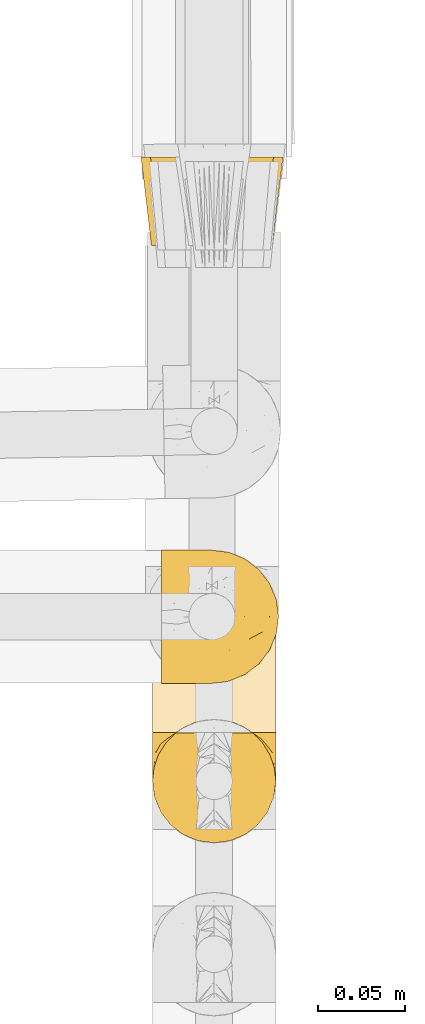
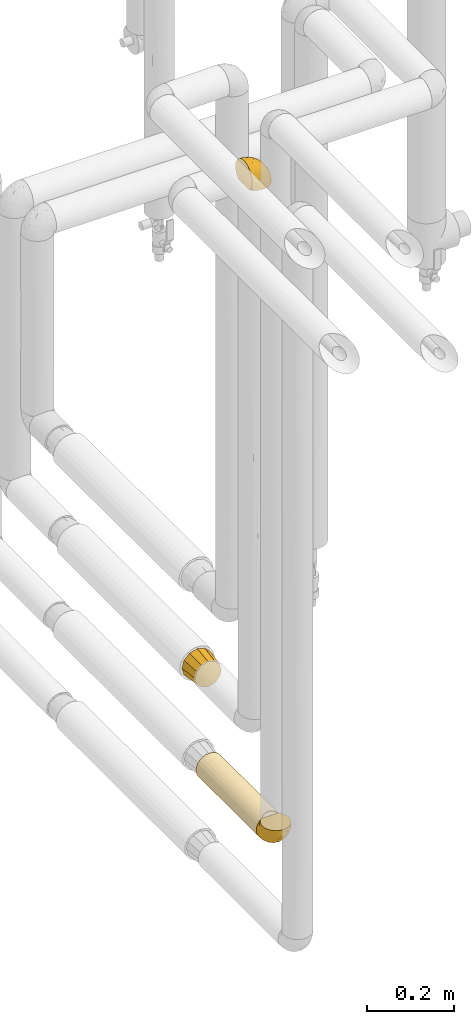
# One storey, part 73 of 827: 4 coverings.
"""IFC2X3 building model written with IfcOpenShell, lengths in millimetres."""

from ifc_helpers import new_model, entity, si_unit, converted_unit, derived_unit, direction, frame, origin, place, context, subcontext, project, spatial, faceted_brep, element, save


model = new_model("IFC2X3")

# Units and contexts
model_context = context("Model", 3, precision=0.01, world=origin(), true_north=direction((6.12303176911189e-17, 1.0)))
body_context = subcontext(model_context, "Body", "Model", "MODEL_VIEW")
ifc_project = project(units=[si_unit("LENGTHUNIT", "METRE", prefix="MILLI"), si_unit("AREAUNIT", "SQUARE_METRE"), si_unit("VOLUMEUNIT", "CUBIC_METRE"), converted_unit("PLANEANGLEUNIT", "DEGREE", entity("IfcRatioMeasure", 0.0174532925199433), si_unit("PLANEANGLEUNIT", "RADIAN"), dimensions=[0, 0, 0, 0, 0, 0, 0]), si_unit("MASSUNIT", "GRAM", prefix="KILO"), derived_unit("MASSDENSITYUNIT", [(si_unit("MASSUNIT", "GRAM", prefix="KILO"), 1), (si_unit("LENGTHUNIT", "METRE"), -3)]), derived_unit("MOMENTOFINERTIAUNIT", [(si_unit("LENGTHUNIT", "METRE"), 4)]), si_unit("TIMEUNIT", "SECOND"), si_unit("FREQUENCYUNIT", "HERTZ"), si_unit("THERMODYNAMICTEMPERATUREUNIT", "DEGREE_CELSIUS"), derived_unit("THERMALTRANSMITTANCEUNIT", [(si_unit("MASSUNIT", "GRAM", prefix="KILO"), 1), (si_unit("THERMODYNAMICTEMPERATUREUNIT", "KELVIN"), -1), (si_unit("TIMEUNIT", "SECOND"), -3)]), derived_unit("VOLUMETRICFLOWRATEUNIT", [(si_unit("LENGTHUNIT", "METRE"), 3), (si_unit("TIMEUNIT", "SECOND"), -1)]), derived_unit("MASSFLOWRATEUNIT", [(si_unit("MASSUNIT", "GRAM", prefix="KILO"), 1), (si_unit("TIMEUNIT", "SECOND"), -1)]), derived_unit("ROTATIONALFREQUENCYUNIT", [(si_unit("TIMEUNIT", "SECOND"), -1)]), si_unit("ELECTRICCURRENTUNIT", "AMPERE"), si_unit("ELECTRICVOLTAGEUNIT", "VOLT"), si_unit("POWERUNIT", "WATT"), si_unit("FORCEUNIT", "NEWTON", prefix="KILO"), si_unit("ILLUMINANCEUNIT", "LUX"), si_unit("LUMINOUSFLUXUNIT", "LUMEN"), si_unit("LUMINOUSINTENSITYUNIT", "CANDELA"), derived_unit("USERDEFINED", [(si_unit("MASSUNIT", "GRAM", prefix="KILO"), -1), (si_unit("LENGTHUNIT", "METRE"), -2), (si_unit("TIMEUNIT", "SECOND"), 3), (si_unit("LUMINOUSFLUXUNIT", "LUMEN"), 1)]), derived_unit("LINEARVELOCITYUNIT", [(si_unit("LENGTHUNIT", "METRE"), 1), (si_unit("TIMEUNIT", "SECOND"), -1)]), si_unit("PRESSUREUNIT", "PASCAL"), derived_unit("USERDEFINED", [(si_unit("LENGTHUNIT", "METRE"), -2), (si_unit("MASSUNIT", "GRAM", prefix="KILO"), 1), (si_unit("TIMEUNIT", "SECOND"), -2)]), derived_unit("LINEARFORCEUNIT", [(si_unit("MASSUNIT", "GRAM", prefix="KILO"), 1), (si_unit("LENGTHUNIT", "METRE"), 1), (si_unit("TIMEUNIT", "SECOND"), -2), (si_unit("LENGTHUNIT", "METRE"), -1)]), derived_unit("PLANARFORCEUNIT", [(si_unit("MASSUNIT", "GRAM", prefix="KILO"), 1), (si_unit("LENGTHUNIT", "METRE"), 1), (si_unit("TIMEUNIT", "SECOND"), -2), (si_unit("LENGTHUNIT", "METRE"), -2)])], contexts=[model_context])

# Site, building, storey
site_placement = place(None, origin())
site = spatial("IfcSite", under=ifc_project, at=site_placement, CompositionType="ELEMENT")
building_placement = place(site_placement, origin())
building = spatial("IfcBuilding", under=site, at=building_placement, CompositionType="ELEMENT")
storey_placement = place(building_placement, frame((0.0, 0.0, 28200.0)))
storey = spatial("IfcBuildingStorey", under=building, at=storey_placement, Name="08", CompositionType="ELEMENT", Elevation=28200.0)

# Coverings
covering_1_placement = place(storey_placement, frame((17896.58, 10716.18, 2621.03)))
element("IfcCovering", 1, at=covering_1_placement, inside=storey, Name=":ADSK_", ObjectType=":ADSK_", PredefinedType="INSULATION", context=body_context, shape_type="Brep", body=[
    faceted_brep([(1.6, 5.41, 47.38), (1.6, 9.99, 54.67), (1.6, 16.08, 60.76), (1.6, 23.37, 65.34), (1.6, 31.49, 68.18), (1.6, 40.05, 69.15), (1.6, 48.61, 68.18), (1.6, 56.73, 65.33), (1.6, 64.02, 60.75), (1.6, 70.11, 54.66), (1.6, 74.69, 47.37), (1.6, 77.53, 39.25), (1.6, 78.5, 30.7), (1.6, 77.63, 22.59), (1.6, 75.08, 14.86), (1.6, 70.97, 7.84), (1.6, 65.47, 1.85), (1.6, 63.27, 1.85), (1.6, 61.53, 1.85), (1.6, 59.57, 1.85), (1.6, 57.6, 1.85), (1.6, 55.63, 1.85), (1.6, 53.67, 1.85), (1.6, 51.7, 1.85), (1.6, 49.73, 1.85), (1.6, 47.54, 1.85), (1.6, 45.34, 1.85), (1.6, 43.15, 1.85), (1.6, 40.96, 1.85), (1.6, 38.76, 1.85), (1.6, 36.57, 1.85), (1.6, 34.37, 1.85), (1.6, 32.18, 1.85), (1.6, 29.98, 1.85), (1.6, 27.79, 1.85), (1.6, 25.6, 1.85), (1.6, 23.4, 1.85), (1.6, 21.21, 1.85), (1.6, 19.01, 1.85), (1.6, 16.82, 1.85), (1.6, 14.62, 1.85), (1.6, 9.12, 7.85), (1.6, 5.0, 14.88), (1.6, 2.46, 22.61), (1.6, 1.6, 30.7), (1.6, 2.56, 39.26), (1.85, 65.47, 1.6), (7.85, 70.97, 1.6), (14.87, 75.09, 1.6), (22.6, 77.63, 1.6), (30.7, 78.5, 1.6), (40.65, 77.19, 1.6), (49.92, 73.34, 1.6), (57.88, 67.23, 1.6), (63.99, 59.27, 1.6), (67.84, 50.0, 1.6), (69.15, 40.05, 1.6), (67.84, 30.09, 1.6), (63.99, 20.82, 1.6), (57.88, 12.86, 1.6), (49.92, 6.75, 1.6), (40.65, 2.91, 1.6), (30.7, 1.6, 1.6), (22.6, 2.46, 1.6), (14.87, 5.0, 1.6), (7.85, 9.12, 1.6), (1.85, 14.62, 1.6), (1.85, 16.82, 1.6), (1.85, 17.8, 1.6), (1.85, 19.39, 1.6), (1.85, 20.98, 1.6), (1.85, 22.57, 1.6), (1.85, 24.16, 1.6), (1.85, 25.75, 1.6), (1.85, 27.33, 1.6), (1.85, 28.92, 1.6), (1.85, 30.51, 1.6), (1.85, 32.1, 1.6), (1.85, 33.69, 1.6), (1.85, 35.28, 1.6), (1.85, 36.87, 1.6), (1.85, 38.46, 1.6), (1.85, 40.05, 1.6), (1.85, 41.63, 1.6), (1.85, 43.22, 1.6), (1.85, 44.81, 1.6), (1.85, 46.4, 1.6), (1.85, 47.99, 1.6), (1.85, 49.58, 1.6), (1.85, 51.17, 1.6), (1.85, 52.76, 1.6), (1.85, 54.72, 1.6), (1.85, 56.69, 1.6), (1.85, 58.88, 1.6), (1.85, 61.08, 1.6), (1.85, 63.27, 1.6), (1.77, 37.77, 1.78), (1.78, 36.07, 1.77), (1.77, 32.96, 1.78), (1.77, 31.36, 1.77), (1.76, 56.52, 1.79), (1.77, 54.96, 1.78), (1.79, 18.75, 1.76), (1.78, 58.07, 1.77), (1.78, 50.37, 1.77), (1.78, 23.36, 1.76), (1.78, 24.95, 1.77), (1.78, 42.43, 1.77), (1.74, 15.97, 1.8), (1.78, 51.96, 1.76), (1.78, 53.47, 1.77), (1.77, 48.63, 1.78), (1.78, 63.93, 1.77), (1.78, 40.93, 1.77), (1.78, 29.72, 1.76), (1.77, 62.4, 1.77), (1.77, 60.92, 1.78), (1.77, 17.31, 1.77), (1.78, 21.74, 1.77), (1.78, 34.56, 1.77), (1.77, 20.18, 1.78), (1.77, 14.62, 1.77), (1.72, 14.62, 1.8), (1.66, 14.62, 1.82), (1.77, 65.47, 1.77), (1.8, 65.47, 1.72), (1.82, 65.47, 1.66), (1.79, 59.5, 1.76), (1.78, 47.1, 1.77), (1.79, 45.61, 1.76), (1.78, 28.18, 1.77), (1.82, 14.62, 1.66), (1.8, 14.62, 1.72), (1.76, 26.61, 1.78), (1.66, 65.47, 1.82), (1.72, 65.47, 1.8), (1.78, 39.32, 1.77), (1.77, 44.12, 1.78), (9.41, 72.26, 3.72), (17.65, 76.57, 7.41), (7.41, 71.77, 6.13), (21.47, 78.5, 21.47), (15.21, 77.9, 19.34), (16.15, 78.5, 26.8), (28.75, 78.5, 8.87), (13.67, 75.52, 9.2), (12.79, 76.13, 12.79), (19.18, 77.81, 14.62), (29.16, 78.5, 7.34), (9.04, 72.4, 5.33), (7.41, 76.56, 17.64), (5.74, 71.77, 7.7), (3.72, 72.25, 9.41), (8.87, 78.5, 28.75), (26.8, 78.5, 16.15), (9.53, 75.75, 14.14), (7.34, 78.5, 29.16), (37.63, 50.46, 57.02), (17.92, 52.75, 64.92), (27.45, 40.05, 64.0), (37.01, 77.7, 11.92), (34.22, 77.66, 19.16), (45.87, 71.02, 28.65), (56.57, 63.45, 24.62), (52.31, 70.55, 15.19), (42.07, 75.57, 18.36), (44.74, 75.57, 9.2), (21.49, 72.61, 46.98), (11.02, 72.61, 50.24), (15.64, 67.24, 56.1), (26.02, 77.74, 28.97), (36.59, 57.43, 54.46), (65.49, 47.19, 21.34), (63.99, 54.76, 18.4), (15.2, 40.05, 66.44), (60.27, 63.45, 12.07), (45.25, 60.1, 45.49), (35.21, 63.72, 50.57), (22.52, 76.83, 36.04), (12.03, 76.34, 42.07), (13.32, 60.51, 62.12), (35.9, 72.59, 37.37), (33.87, 76.05, 29.39), (25.73, 66.15, 53.59), (26.34, 60.51, 58.06), (46.78, 51.88, 49.27), (59.54, 55.34, 29.63), (60.18, 48.67, 33.21), (53.93, 53.89, 40.1), (53.36, 46.73, 44.08), (49.36, 40.05, 49.36), (38.4, 40.05, 56.68), (66.44, 40.05, 15.2), (50.09, 63.95, 35.57), (41.08, 67.24, 41.7), (31.14, 69.62, 46.4), (28.19, 73.6, 41.41), (64.0, 40.05, 27.45), (56.68, 40.05, 38.4), (43.9, 4.52, 12.99), (65.46, 32.72, 21.33), (52.22, 27.18, 42.89), (37.61, 29.63, 57.04), (15.64, 12.86, 56.11), (13.31, 19.59, 62.13), (50.02, 9.54, 21.89), (59.28, 16.64, 16.62), (53.05, 17.48, 32.9), (21.48, 7.49, 46.99), (11.01, 7.49, 50.25), (12.03, 3.75, 42.08), (41.02, 20.75, 49.91), (35.39, 2.33, 15.6), (26.8, 1.6, 16.15), (28.75, 1.6, 8.87), (7.34, 1.6, 29.16), (65.81, 26.94, 13.16), (53.28, 9.54, 10.83), (59.8, 31.21, 33.8), (61.82, 25.33, 25.02), (17.91, 27.35, 64.92), (41.4, 8.17, 32.83), (40.48, 4.3, 20.56), (26.34, 19.59, 58.07), (31.68, 2.23, 21.46), (27.68, 2.45, 28.1), (16.15, 1.6, 26.8), (21.47, 1.6, 21.47), (28.05, 12.86, 51.29), (22.54, 3.27, 36.04), (8.87, 1.6, 28.75), (37.3, 2.29, 8.45), (41.07, 12.86, 41.73), (32.24, 6.89, 39.27), (47.4, 12.43, 33.56), (35.77, 4.1, 27.29), (17.65, 3.53, 7.41), (11.06, 6.88, 3.51), (8.55, 8.16, 4.68), (6.63, 9.02, 5.52), (12.77, 5.0, 8.75), (12.79, 3.96, 12.79), (7.41, 3.52, 17.65), (18.97, 2.4, 13.9), (3.72, 7.83, 9.42), (5.76, 8.32, 7.68), (15.21, 2.19, 19.33), (9.52, 4.34, 14.13)], [[[0, 1, 2, 3, 4, 5, 6, 7, 8, 9, 10, 11, 12, 13, 14, 15, 16, 17, 18, 19, 20, 21, 22, 23, 24, 25, 26, 27, 28, 29, 30, 31, 32, 33, 34, 35, 36, 37, 38, 39, 40, 41, 42, 43, 44, 45]], [[46, 47, 48, 49, 50, 51, 52, 53, 54, 55, 56, 57, 58, 59, 60, 61, 62, 63, 64, 65, 66, 67, 68, 69, 70, 71, 72, 73, 74, 75, 76, 77, 78, 79, 80, 81, 82, 83, 84, 85, 86, 87, 88, 89, 90, 91, 92, 93, 94, 95]], [[96, 97, 30]], [[98, 77, 99]], [[100, 101, 21]], [[69, 68, 102]], [[20, 19, 103]], [[24, 23, 104]], [[20, 103, 100]], [[72, 105, 106]], [[84, 83, 107]], [[89, 88, 104]], [[108, 67, 66]], [[109, 110, 90]], [[111, 25, 24]], [[112, 17, 16]], [[82, 113, 83]], [[109, 23, 22]], [[114, 76, 75]], [[105, 36, 106]], [[104, 111, 24]], [[18, 115, 116]], [[97, 96, 80]], [[67, 108, 117]], [[105, 71, 118]], [[31, 97, 119]], [[102, 120, 69]], [[108, 121, 122, 123, 40]], [[112, 95, 115]], [[17, 115, 18]], [[94, 116, 115]], [[117, 68, 67]], [[38, 117, 39]], [[112, 124, 125, 126, 46]], [[17, 112, 115]], [[70, 120, 118]], [[39, 117, 108]], [[120, 38, 37]], [[120, 37, 118]], [[120, 70, 69]], [[116, 94, 127]], [[128, 86, 129]], [[117, 38, 102]], [[74, 130, 75]], [[99, 33, 32]], [[115, 95, 94]], [[39, 108, 40]], [[108, 66, 131, 132, 121]], [[105, 72, 71]], [[118, 37, 36]], [[71, 70, 118]], [[35, 106, 36]], [[36, 105, 118]], [[35, 133, 106]], [[74, 73, 133]], [[106, 133, 73]], [[99, 114, 33]], [[133, 35, 34]], [[73, 72, 106]], [[95, 112, 46]], [[112, 16, 134, 135, 124]], [[130, 114, 75]], [[99, 76, 114]], [[114, 130, 33]], [[34, 33, 130]], [[78, 77, 98]], [[98, 119, 78]], [[130, 133, 34]], [[133, 130, 74]], [[79, 97, 80]], [[98, 99, 32]], [[98, 32, 31]], [[77, 76, 99]], [[97, 79, 119]], [[136, 96, 29]], [[30, 97, 31]], [[136, 29, 28]], [[81, 80, 96]], [[29, 96, 30]], [[31, 119, 98]], [[119, 79, 78]], [[96, 136, 81]], [[82, 81, 136]], [[113, 107, 83]], [[84, 107, 137]], [[107, 27, 137]], [[113, 28, 107]], [[27, 107, 28]], [[85, 84, 137]], [[137, 27, 26]], [[113, 136, 28]], [[136, 113, 82]], [[109, 89, 104]], [[86, 85, 129]], [[89, 109, 90]], [[111, 87, 128]], [[26, 129, 137]], [[88, 111, 104]], [[25, 111, 128]], [[22, 110, 109]], [[23, 109, 104]], [[110, 91, 90]], [[100, 92, 101]], [[110, 22, 101]], [[91, 110, 101]], [[116, 19, 18]], [[111, 88, 87]], [[127, 103, 19]], [[25, 128, 26]], [[86, 128, 87]], [[128, 129, 26]], [[137, 129, 85]], [[120, 102, 38]], [[117, 102, 68]], [[91, 101, 92]], [[21, 101, 22]], [[93, 92, 103]], [[100, 21, 20]], [[100, 103, 92]], [[127, 93, 103]], [[93, 127, 94]], [[116, 127, 19]], [[126, 138, 47]], [[48, 138, 139]], [[140, 125, 124]], [[141, 142, 143]], [[144, 49, 139]], [[145, 140, 146]], [[48, 139, 49]], [[139, 145, 147]], [[49, 144, 148, 50]], [[126, 125, 149]], [[14, 13, 150]], [[151, 146, 140]], [[149, 140, 145]], [[152, 151, 135]], [[152, 14, 150]], [[16, 15, 134]], [[13, 153, 150]], [[124, 151, 140]], [[141, 147, 142]], [[14, 152, 15]], [[15, 152, 134]], [[47, 46, 126]], [[139, 154, 144]], [[138, 48, 47]], [[125, 140, 149]], [[135, 134, 152]], [[146, 155, 142]], [[145, 146, 147]], [[149, 139, 138]], [[147, 141, 154]], [[147, 146, 142]], [[139, 147, 154]], [[139, 149, 145]], [[149, 138, 126]], [[155, 146, 151]], [[150, 143, 142]], [[152, 155, 151]], [[150, 142, 155]], [[13, 12, 156, 153]], [[153, 143, 150]], [[152, 150, 155]], [[151, 124, 135]], [[157, 158, 159]], [[160, 154, 161]], [[162, 163, 164]], [[165, 166, 160]], [[167, 168, 169]], [[141, 170, 161]], [[156, 12, 11]], [[158, 157, 171]], [[172, 55, 173]], [[158, 6, 174]], [[175, 54, 53]], [[52, 166, 164]], [[52, 164, 53]], [[54, 175, 173]], [[166, 52, 51]], [[176, 177, 171]], [[178, 143, 179]], [[156, 11, 179]], [[8, 7, 180]], [[169, 9, 8]], [[179, 143, 153, 156]], [[179, 11, 10]], [[168, 179, 10]], [[181, 162, 182]], [[179, 167, 178]], [[183, 184, 177]], [[183, 169, 184]], [[176, 171, 185]], [[172, 186, 187]], [[158, 7, 6]], [[159, 158, 174]], [[184, 180, 158]], [[54, 173, 55]], [[180, 169, 8]], [[188, 189, 187]], [[9, 168, 10]], [[186, 188, 187]], [[190, 157, 159, 191]], [[55, 172, 192]], [[176, 193, 194]], [[161, 170, 182]], [[162, 164, 165]], [[175, 164, 163]], [[51, 50, 148]], [[167, 195, 196]], [[178, 182, 170]], [[6, 5, 174]], [[158, 180, 7]], [[169, 180, 184]], [[169, 168, 9]], [[179, 168, 167]], [[182, 162, 165]], [[162, 194, 193]], [[161, 165, 160]], [[195, 181, 196]], [[192, 172, 197]], [[192, 56, 55]], [[189, 190, 198]], [[198, 197, 187]], [[172, 187, 197]], [[185, 189, 188]], [[198, 187, 189]], [[186, 172, 173]], [[173, 163, 186]], [[193, 186, 163]], [[176, 185, 188]], [[185, 157, 190]], [[188, 186, 193]], [[177, 176, 194]], [[188, 193, 176]], [[162, 193, 163]], [[195, 177, 194]], [[171, 177, 184]], [[181, 195, 194]], [[183, 167, 169]], [[162, 181, 194]], [[196, 182, 178]], [[158, 171, 184]], [[171, 157, 185]], [[177, 195, 183]], [[167, 183, 195]], [[182, 196, 181]], [[178, 170, 143]], [[178, 167, 196]], [[164, 175, 53]], [[173, 175, 163]], [[160, 51, 148]], [[164, 166, 165]], [[51, 160, 166]], [[160, 148, 144, 154]], [[141, 161, 154]], [[182, 165, 161]], [[190, 189, 185]], [[143, 170, 141]], [[60, 199, 61]], [[197, 200, 192]], [[201, 190, 202]], [[200, 57, 192]], [[203, 204, 2]], [[205, 206, 207]], [[208, 209, 210]], [[211, 207, 201]], [[212, 213, 214]], [[45, 215, 210]], [[216, 206, 58]], [[45, 44, 215]], [[59, 217, 60]], [[60, 217, 199]], [[0, 45, 210]], [[218, 201, 219]], [[202, 159, 220]], [[205, 221, 222]], [[223, 204, 203]], [[1, 203, 2]], [[57, 200, 216]], [[220, 3, 204]], [[220, 174, 4]], [[1, 0, 209]], [[212, 224, 213]], [[225, 226, 227]], [[228, 223, 203]], [[208, 210, 229]], [[210, 226, 229]], [[3, 220, 4]], [[58, 206, 59]], [[209, 203, 1]], [[202, 220, 223]], [[228, 203, 208]], [[202, 211, 201]], [[3, 2, 204]], [[202, 190, 191, 159]], [[210, 215, 230, 226]], [[199, 212, 231]], [[232, 233, 221]], [[233, 208, 229]], [[207, 206, 219]], [[217, 206, 205]], [[227, 224, 225]], [[233, 232, 228]], [[201, 207, 219]], [[234, 232, 221]], [[218, 219, 200]], [[202, 223, 211]], [[174, 220, 159]], [[174, 5, 4]], [[61, 231, 62]], [[220, 204, 223]], [[210, 209, 0]], [[203, 209, 208]], [[225, 233, 229]], [[224, 227, 213]], [[221, 233, 235]], [[57, 56, 192]], [[198, 218, 197]], [[200, 219, 216]], [[201, 198, 190]], [[197, 218, 200]], [[198, 201, 218]], [[206, 216, 219]], [[58, 57, 216]], [[231, 212, 214]], [[222, 212, 199]], [[228, 211, 223]], [[207, 211, 232]], [[62, 231, 214]], [[199, 231, 61]], [[233, 228, 208]], [[211, 228, 232]], [[222, 221, 235]], [[234, 205, 207]], [[206, 217, 59]], [[199, 217, 205]], [[205, 222, 199]], [[224, 222, 235]], [[222, 224, 212]], [[224, 235, 225]], [[233, 225, 235]], [[226, 225, 229]], [[205, 234, 221]], [[207, 232, 234]], [[63, 214, 236]], [[214, 213, 236]], [[214, 63, 62]], [[237, 236, 238]], [[238, 132, 131]], [[236, 237, 64]], [[239, 240, 241]], [[63, 236, 64]], [[131, 66, 65]], [[237, 131, 65]], [[242, 230, 43]], [[237, 65, 64]], [[239, 121, 132]], [[42, 242, 43]], [[241, 240, 243]], [[41, 123, 244]], [[43, 230, 215, 44]], [[244, 122, 245]], [[227, 246, 243]], [[245, 241, 247]], [[121, 239, 245]], [[41, 40, 123]], [[132, 238, 239]], [[244, 42, 41]], [[131, 237, 238]], [[240, 239, 238]], [[245, 239, 241]], [[247, 241, 246]], [[247, 244, 245]], [[238, 236, 240]], [[243, 236, 213]], [[236, 243, 240]], [[246, 241, 243]], [[243, 213, 227]], [[226, 242, 246]], [[227, 226, 246]], [[246, 242, 247]], [[244, 247, 242]], [[242, 226, 230]], [[42, 244, 242]], [[122, 244, 123]], [[122, 121, 245]]]),
])
covering_2_placement = place(storey_placement, frame((17884.68, 10970.86, 1059.92)))
element("IfcCovering", 2, at=covering_2_placement, inside=storey, Name=":ADSK_", ObjectType=":ADSK_", PredefinedType="INSULATION", context=body_context, shape_type="Brep", body=[
    faceted_brep([(12.28, 0.0, 60.1), (9.94, 0.0, 51.35), (7.6, 0.0, 42.6), (9.94, 0.0, 33.85), (12.28, 0.0, 25.1), (18.69, 0.0, 18.69), (25.1, 0.0, 12.28), (33.85, 0.0, 9.94), (42.6, 0.0, 7.6), (51.35, 0.0, 9.94), (60.1, 0.0, 12.28), (66.5, 0.0, 18.69), (72.91, 0.0, 25.1), (75.25, 0.0, 33.85), (77.6, 0.0, 42.6), (75.25, 0.0, 51.35), (72.91, 0.0, 60.1), (66.5, 0.0, 66.5), (60.1, 0.0, 72.91), (51.35, 0.0, 75.25), (42.6, 0.0, 77.6), (33.85, 0.0, 75.25), (25.1, 0.0, 72.91), (18.69, 0.0, 66.5), (70.6, 51.0, 70.6), (78.1, 51.0, 63.1), (79.76, 51.0, 56.92), (81.68, 51.0, 49.76), (83.6, 51.0, 42.6), (81.68, 51.0, 35.43), (79.76, 51.0, 28.27), (78.1, 51.0, 22.1), (70.6, 51.0, 14.59), (63.1, 51.0, 7.09), (56.92, 51.0, 5.43), (49.76, 51.0, 3.51), (42.6, 51.0, 1.6), (35.43, 51.0, 3.51), (28.27, 51.0, 5.43), (22.1, 51.0, 7.09), (14.59, 51.0, 14.59), (7.09, 51.0, 22.1), (5.43, 51.0, 28.27), (3.51, 51.0, 35.43), (1.6, 51.0, 42.6), (3.51, 51.0, 49.76), (5.43, 51.0, 56.92), (7.09, 51.0, 63.1), (14.59, 51.0, 70.6), (22.1, 51.0, 78.1), (28.27, 51.0, 79.76), (35.43, 51.0, 81.68), (42.6, 51.0, 83.6), (49.76, 51.0, 81.68), (56.92, 51.0, 79.76), (63.1, 51.0, 78.1)], [[[0, 1, 2, 3, 4, 5, 6, 7, 8, 9, 10, 11, 12, 13, 14, 15, 16, 17, 18, 19, 20, 21, 22, 23]], [[24, 25, 26, 27, 28, 29, 30, 31, 32, 33, 34, 35, 36, 37, 38, 39, 40, 41, 42, 43, 44, 45, 46, 47, 48, 49, 50, 51, 52, 53, 54, 55]], [[6, 39, 38, 37, 36, 8, 7]], [[41, 40, 39, 6, 5, 4]], [[43, 42, 41, 4, 3, 2, 44]], [[12, 31, 30, 29, 28, 14, 13]], [[33, 32, 31, 12, 11, 10]], [[35, 34, 33, 10, 9, 8, 36]], [[18, 55, 54, 53, 52, 20, 19]], [[25, 24, 55, 18, 17, 16]], [[27, 26, 25, 16, 15, 14, 28]], [[0, 47, 46, 45, 44, 2, 1]], [[49, 48, 47, 0, 23, 22]], [[51, 50, 49, 22, 21, 20, 52]]]),
])
covering_3_placement = place(storey_placement, frame((17891.28, 10687.61, 808.5)))
element("IfcCovering", 3, at=covering_3_placement, inside=storey, Name=":ADSK_", ObjectType=":ADSK_", PredefinedType="INSULATION", context=body_context, shape_type="Brep", body=[
    faceted_brep([(12.04, 1.6, 12.04), (19.42, 1.6, 6.37), (28.02, 1.6, 2.81), (37.25, 1.6, 1.6), (46.47, 1.6, 2.81), (55.07, 1.6, 6.37), (62.45, 1.6, 12.04), (68.12, 1.6, 19.42), (71.68, 1.6, 28.02), (72.9, 1.6, 37.25), (71.99, 1.6, 45.24), (69.32, 1.6, 52.81), (65.02, 1.6, 59.6), (59.31, 1.6, 65.25), (15.18, 1.6, 65.25), (9.47, 1.6, 59.6), (5.17, 1.6, 52.81), (2.5, 1.6, 45.24), (1.6, 1.6, 37.25), (2.81, 1.6, 28.02), (6.37, 1.6, 19.42), (28.02, 280.6, 2.81), (19.42, 280.6, 6.37), (12.04, 280.6, 12.04), (6.37, 280.6, 19.42), (2.81, 280.6, 28.02), (1.6, 280.6, 37.25), (2.81, 280.6, 46.47), (6.37, 280.6, 55.07), (12.04, 280.6, 62.45), (19.42, 280.6, 68.12), (28.02, 280.6, 71.68), (37.25, 280.6, 72.9), (46.47, 280.6, 71.68), (55.07, 280.6, 68.12), (62.45, 280.6, 62.45), (68.12, 280.6, 55.07), (71.68, 280.6, 46.47), (72.9, 280.6, 37.25), (71.68, 280.6, 28.02), (68.12, 280.6, 19.42), (62.45, 280.6, 12.04), (55.07, 280.6, 6.37), (46.47, 280.6, 2.81), (37.25, 280.6, 1.6), (48.92, 7.28, 70.93), (43.17, 8.75, 72.4), (37.25, 9.25, 72.9), (54.35, 4.87, 68.52), (31.32, 8.75, 72.4), (25.57, 7.28, 70.93), (20.14, 4.87, 68.52)], [[[0, 1, 2, 3, 4, 5, 6, 7, 8, 9, 10, 11, 12, 13, 14, 15, 16, 17, 18, 19, 20]], [[21, 22, 23, 24, 25, 26, 27, 28, 29, 30, 31, 32, 33, 34, 35, 36, 37, 38, 39, 40, 41, 42, 43, 44]], [[25, 24, 20, 19]], [[26, 25, 19, 18]], [[0, 20, 24, 23]], [[2, 1, 22, 21]], [[3, 2, 21, 44]], [[23, 22, 1, 0]], [[4, 3, 44, 43]], [[5, 4, 43, 42]], [[42, 41, 6, 5]], [[8, 7, 40, 39]], [[9, 8, 39, 38]], [[41, 40, 7, 6]], [[10, 38, 37]], [[11, 37, 36]], [[12, 36, 35]], [[9, 38, 10]], [[10, 37, 11]], [[36, 12, 11]], [[35, 13, 12]], [[45, 34, 33]], [[33, 32, 46]], [[47, 46, 32]], [[48, 13, 34]], [[46, 45, 33]], [[48, 34, 45]], [[34, 13, 35]], [[49, 47, 32]], [[49, 32, 31]], [[50, 31, 30]], [[50, 49, 31]], [[14, 51, 30]], [[50, 30, 51]], [[30, 29, 14]], [[15, 29, 28]], [[16, 28, 27]], [[17, 27, 26]], [[15, 28, 16]], [[16, 27, 17]], [[26, 18, 17]], [[29, 15, 14]], [[45, 46, 47, 49, 50, 51, 14, 13, 48]]]),
])
covering_4_placement = place(storey_placement, frame((17891.28, 10623.96, 808.5)))
element("IfcCovering", 4, at=covering_4_placement, inside=storey, Name=":ADSK_", ObjectType=":ADSK_", PredefinedType="INSULATION", context=body_context, shape_type="Brep", body=[
    faceted_brep([(69.36, 65.25, 21.77), (65.11, 65.25, 15.01), (59.47, 65.25, 9.37), (52.71, 65.25, 5.12), (45.17, 65.25, 2.49), (37.25, 65.25, 1.6), (29.31, 65.25, 2.49), (21.77, 65.25, 5.13), (15.01, 65.25, 9.38), (9.37, 65.25, 15.02), (5.12, 65.25, 21.78), (2.49, 65.25, 29.32), (1.6, 65.25, 37.25), (2.48, 65.25, 45.15), (5.1, 65.25, 52.65), (9.31, 65.25, 59.39), (14.9, 65.25, 65.02), (16.96, 65.25, 65.02), (18.43, 65.25, 65.02), (20.19, 65.25, 65.02), (21.96, 65.25, 65.02), (23.72, 65.25, 65.02), (25.49, 65.25, 65.02), (27.25, 65.25, 65.02), (29.02, 65.25, 65.02), (30.78, 65.25, 65.02), (32.55, 65.25, 65.02), (34.31, 65.25, 65.02), (36.08, 65.25, 65.02), (37.84, 65.25, 65.02), (39.61, 65.25, 65.02), (41.37, 65.25, 65.02), (43.14, 65.25, 65.02), (45.19, 65.25, 65.02), (47.25, 65.25, 65.02), (49.31, 65.25, 65.02), (51.36, 65.25, 65.02), (53.42, 65.25, 65.02), (55.48, 65.25, 65.02), (57.53, 65.25, 65.02), (59.59, 65.25, 65.02), (65.19, 65.25, 59.38), (69.4, 65.25, 52.64), (72.01, 65.25, 45.13), (72.9, 65.25, 37.25), (72.0, 65.25, 29.31), (14.9, 65.02, 65.25), (9.3, 59.38, 65.25), (5.09, 52.65, 65.25), (2.48, 45.14, 65.25), (1.6, 37.25, 65.25), (2.81, 28.02, 65.25), (6.37, 19.42, 65.25), (12.04, 12.04, 65.25), (19.42, 6.37, 65.25), (28.02, 2.81, 65.25), (37.25, 1.6, 65.25), (46.47, 2.81, 65.25), (55.07, 6.37, 65.25), (62.45, 12.04, 65.25), (68.12, 19.42, 65.25), (71.68, 28.02, 65.25), (72.9, 37.25, 65.25), (72.01, 45.14, 65.25), (69.4, 52.65, 65.25), (65.19, 59.38, 65.25), (59.59, 65.02, 65.25), (58.56, 65.02, 65.25), (56.8, 65.02, 65.25), (55.4, 65.02, 65.25), (54.0, 65.02, 65.25), (52.61, 65.02, 65.25), (51.21, 65.02, 65.25), (49.81, 65.02, 65.25), (48.42, 65.02, 65.25), (47.02, 65.02, 65.25), (45.62, 65.02, 65.25), (44.23, 65.02, 65.25), (42.83, 65.02, 65.25), (41.43, 65.02, 65.25), (40.04, 65.02, 65.25), (38.64, 65.02, 65.25), (37.25, 65.02, 65.25), (35.48, 65.02, 65.25), (33.72, 65.02, 65.25), (31.95, 65.02, 65.25), (30.19, 65.02, 65.25), (28.42, 65.02, 65.25), (26.66, 65.02, 65.25), (24.89, 65.02, 65.25), (23.13, 65.02, 65.25), (21.07, 65.02, 65.25), (19.01, 65.02, 65.25), (16.96, 65.02, 65.25), (50.36, 65.09, 65.08), (51.91, 65.08, 65.09), (27.73, 65.08, 65.09), (29.06, 65.08, 65.1), (23.0, 65.1, 65.08), (39.29, 65.08, 65.09), (16.3, 65.09, 65.09), (17.69, 65.09, 65.09), (42.09, 65.09, 65.09), (43.53, 65.08, 65.1), (58.23, 65.1, 65.08), (59.59, 65.09, 65.09), (46.32, 65.1, 65.08), (47.68, 65.08, 65.09), (19.0, 65.09, 65.08), (30.39, 65.09, 65.09), (31.67, 65.1, 65.07), (37.94, 65.08, 65.1), (36.57, 65.08, 65.09), (45.01, 65.08, 65.1), (35.19, 65.11, 65.07), (26.37, 65.1, 65.07), (25.1, 65.09, 65.09), (56.91, 65.1, 65.08), (40.68, 65.09, 65.09), (32.77, 65.06, 65.13), (20.34, 65.08, 65.1), (21.67, 65.08, 65.09), (33.92, 65.09, 65.09), (53.39, 65.08, 65.1), (54.7, 65.09, 65.09), (14.9, 65.09, 65.09), (49.03, 65.08, 65.09), (3.58, 53.73, 53.74), (6.24, 58.66, 57.19), (1.6, 41.0, 51.25), (1.6, 38.71, 59.77), (1.6, 51.25, 41.0), (9.92, 61.64, 61.64), (1.6, 46.12, 46.12), (1.6, 59.77, 38.71), (27.59, 31.28, 13.0), (25.47, 49.86, 5.55), (37.25, 40.89, 6.44), (2.33, 31.44, 55.39), (2.37, 34.1, 48.48), (8.53, 23.33, 39.63), (15.54, 13.33, 43.5), (8.96, 17.24, 52.38), (4.31, 26.77, 49.31), (4.31, 24.24, 58.01), (7.06, 46.39, 22.23), (7.06, 56.32, 19.14), (12.03, 51.97, 13.73), (2.3, 41.92, 39.1), (21.13, 32.23, 15.38), (30.63, 5.01, 46.7), (23.6, 6.41, 49.4), (37.25, 52.55, 4.12), (15.54, 9.84, 55.35), (18.65, 24.05, 23.83), (15.3, 33.5, 19.0), (3.14, 45.31, 32.44), (3.59, 55.32, 26.73), (18.27, 54.18, 8.12), (7.07, 32.73, 31.34), (3.86, 34.55, 38.81), (13.04, 42.44, 16.11), (18.27, 41.89, 11.96), (26.27, 22.65, 20.31), (23.06, 10.6, 38.81), (29.25, 10.01, 35.48), (24.41, 15.9, 28.94), (31.04, 16.46, 25.21), (37.25, 20.24, 20.24), (37.25, 30.56, 13.34), (37.25, 4.12, 52.55), (15.08, 19.45, 33.16), (12.03, 27.92, 27.33), (9.82, 37.29, 22.86), (6.14, 40.02, 27.48), (37.25, 6.44, 40.89), (37.25, 13.34, 30.56), (70.18, 25.04, 54.41), (44.04, 5.04, 46.71), (49.17, 17.52, 26.31), (46.9, 31.3, 12.98), (62.45, 51.97, 13.72), (56.21, 54.19, 8.12), (65.53, 19.41, 46.04), (58.95, 10.78, 51.06), (58.17, 16.67, 35.69), (67.43, 46.4, 22.22), (67.43, 56.32, 19.13), (70.89, 55.32, 26.72), (55.13, 28.05, 19.65), (72.21, 32.97, 51.87), (72.9, 41.0, 51.25), (72.9, 39.12, 58.25), (72.9, 59.77, 38.71), (49.42, 4.71, 54.36), (65.53, 16.32, 56.5), (45.41, 10.37, 34.9), (50.89, 8.45, 43.16), (49.01, 49.86, 5.54), (66.8, 27.54, 35.66), (70.39, 28.28, 47.21), (56.21, 41.9, 11.95), (72.31, 36.5, 46.27), (72.1, 40.35, 39.95), (72.9, 51.25, 41.0), (72.9, 46.12, 46.12), (62.45, 40.24, 18.27), (71.35, 45.3, 32.43), (72.26, 31.14, 58.69), (62.45, 27.93, 27.31), (67.99, 36.19, 29.52), (62.85, 21.94, 35.02), (70.57, 32.75, 40.81), (70.91, 53.73, 53.74), (68.25, 57.19, 58.66), (64.57, 61.64, 61.64)], [[[0, 1, 2, 3, 4, 5, 6, 7, 8, 9, 10, 11, 12, 13, 14, 15, 16, 17, 18, 19, 20, 21, 22, 23, 24, 25, 26, 27, 28, 29, 30, 31, 32, 33, 34, 35, 36, 37, 38, 39, 40, 41, 42, 43, 44, 45]], [[46, 47, 48, 49, 50, 51, 52, 53, 54, 55, 56, 57, 58, 59, 60, 61, 62, 63, 64, 65, 66, 67, 68, 69, 70, 71, 72, 73, 74, 75, 76, 77, 78, 79, 80, 81, 82, 83, 84, 85, 86, 87, 88, 89, 90, 91, 92, 93]], [[94, 72, 95]], [[96, 87, 97]], [[20, 98, 21]], [[99, 81, 80]], [[100, 93, 101]], [[102, 103, 32]], [[104, 105, 40]], [[67, 105, 104]], [[106, 107, 34]], [[18, 101, 108]], [[109, 85, 110]], [[36, 94, 95]], [[81, 111, 82]], [[29, 28, 112]], [[17, 101, 18]], [[103, 113, 33]], [[24, 96, 97]], [[28, 114, 112]], [[115, 22, 116]], [[31, 102, 32]], [[68, 104, 117]], [[31, 118, 102]], [[84, 119, 85]], [[120, 91, 121]], [[23, 22, 115]], [[114, 27, 122]], [[123, 37, 95]], [[117, 124, 69]], [[67, 66, 105]], [[104, 39, 117]], [[123, 124, 37]], [[100, 17, 16]], [[100, 125, 46]], [[17, 100, 101]], [[107, 126, 35]], [[92, 108, 101]], [[115, 88, 96]], [[114, 122, 83]], [[101, 93, 92]], [[93, 100, 46]], [[16, 125, 100]], [[108, 19, 18]], [[120, 121, 19]], [[108, 92, 120]], [[19, 108, 120]], [[67, 104, 68]], [[39, 104, 40]], [[69, 68, 117]], [[117, 39, 38]], [[70, 124, 123]], [[124, 70, 69]], [[38, 124, 117]], [[124, 38, 37]], [[72, 71, 95]], [[71, 123, 95]], [[71, 70, 123]], [[126, 94, 35]], [[37, 36, 95]], [[75, 74, 107]], [[73, 72, 94]], [[94, 36, 35]], [[94, 126, 73]], [[74, 73, 126]], [[106, 76, 75]], [[76, 106, 113]], [[113, 106, 33]], [[107, 35, 34]], [[106, 34, 33]], [[126, 107, 74]], [[107, 106, 75]], [[78, 77, 103]], [[77, 113, 103]], [[77, 76, 113]], [[102, 78, 103]], [[33, 32, 103]], [[80, 79, 118]], [[102, 118, 79]], [[112, 111, 29]], [[118, 31, 30]], [[79, 78, 102]], [[99, 111, 81]], [[112, 82, 111]], [[111, 99, 29]], [[30, 29, 99]], [[112, 83, 82]], [[27, 114, 28]], [[99, 118, 30]], [[118, 99, 80]], [[114, 83, 112]], [[84, 83, 122]], [[109, 110, 25]], [[122, 27, 26]], [[119, 110, 85]], [[20, 19, 121]], [[25, 110, 26]], [[91, 120, 92]], [[90, 98, 121]], [[121, 91, 90]], [[23, 115, 96]], [[88, 115, 116]], [[116, 98, 89]], [[89, 88, 116]], [[23, 96, 24]], [[87, 96, 88]], [[25, 24, 109]], [[97, 87, 86]], [[90, 89, 98]], [[116, 22, 21]], [[122, 26, 119]], [[86, 85, 109]], [[109, 97, 86]], [[97, 109, 24]], [[110, 119, 26]], [[122, 119, 84]], [[121, 98, 20]], [[21, 98, 116]], [[48, 127, 49]], [[48, 47, 128]], [[49, 129, 130, 50]], [[129, 49, 127]], [[131, 127, 13]], [[46, 125, 132]], [[16, 15, 132]], [[127, 128, 14]], [[127, 131, 133, 129]], [[14, 13, 127]], [[13, 12, 134, 131]], [[46, 132, 47]], [[48, 128, 127]], [[47, 132, 128]], [[15, 128, 132]], [[125, 16, 132]], [[15, 14, 128]], [[135, 136, 137]], [[138, 129, 139]], [[140, 141, 142]], [[143, 144, 138]], [[145, 146, 147]], [[133, 148, 139]], [[134, 12, 11]], [[136, 135, 149]], [[150, 55, 151]], [[136, 6, 152]], [[153, 54, 53]], [[52, 144, 142]], [[52, 142, 53]], [[54, 153, 151]], [[144, 52, 51]], [[154, 155, 149]], [[156, 131, 157]], [[134, 11, 157]], [[8, 7, 158]], [[147, 9, 8]], [[157, 131, 134]], [[157, 11, 10]], [[146, 157, 10]], [[159, 140, 160]], [[157, 145, 156]], [[161, 162, 155]], [[161, 147, 162]], [[154, 149, 163]], [[150, 164, 165]], [[136, 7, 6]], [[137, 136, 152]], [[162, 158, 136]], [[54, 151, 55]], [[158, 147, 8]], [[166, 167, 165]], [[9, 146, 10]], [[164, 166, 165]], [[168, 135, 137, 169]], [[55, 150, 170]], [[154, 171, 172]], [[139, 148, 160]], [[140, 142, 143]], [[153, 142, 141]], [[51, 50, 130]], [[145, 173, 174]], [[156, 160, 148]], [[6, 5, 152]], [[136, 158, 7]], [[147, 158, 162]], [[147, 146, 9]], [[157, 146, 145]], [[160, 140, 143]], [[140, 172, 171]], [[139, 143, 138]], [[173, 159, 174]], [[170, 150, 175]], [[170, 56, 55]], [[167, 168, 176]], [[176, 175, 165]], [[150, 165, 175]], [[163, 167, 166]], [[176, 165, 167]], [[164, 150, 151]], [[151, 141, 164]], [[171, 164, 141]], [[154, 163, 166]], [[163, 135, 168]], [[166, 164, 171]], [[155, 154, 172]], [[166, 171, 154]], [[140, 171, 141]], [[173, 155, 172]], [[149, 155, 162]], [[159, 173, 172]], [[161, 145, 147]], [[140, 159, 172]], [[174, 160, 156]], [[136, 149, 162]], [[149, 135, 163]], [[155, 173, 161]], [[145, 161, 173]], [[160, 174, 159]], [[156, 148, 131]], [[156, 145, 174]], [[142, 153, 53]], [[151, 153, 141]], [[138, 51, 130]], [[142, 144, 143]], [[51, 138, 144]], [[129, 138, 130]], [[133, 139, 129]], [[160, 143, 139]], [[168, 167, 163]], [[131, 148, 133]], [[60, 177, 61]], [[175, 178, 170]], [[179, 168, 180]], [[178, 57, 170]], [[181, 182, 2]], [[183, 184, 185]], [[186, 187, 188]], [[189, 185, 179]], [[190, 191, 192]], [[45, 193, 188]], [[194, 184, 58]], [[45, 44, 193]], [[59, 195, 60]], [[60, 195, 177]], [[0, 45, 188]], [[196, 179, 197]], [[180, 137, 198]], [[183, 199, 200]], [[201, 182, 181]], [[1, 181, 2]], [[57, 178, 194]], [[198, 3, 182]], [[198, 152, 4]], [[1, 0, 187]], [[190, 202, 191]], [[203, 204, 205]], [[206, 201, 181]], [[186, 188, 207]], [[188, 204, 207]], [[3, 198, 4]], [[58, 184, 59]], [[187, 181, 1]], [[180, 198, 201]], [[206, 181, 186]], [[180, 189, 179]], [[3, 2, 182]], [[180, 168, 169, 137]], [[204, 188, 193]], [[177, 190, 208]], [[209, 210, 199]], [[210, 186, 207]], [[185, 184, 197]], [[195, 184, 183]], [[205, 202, 203]], [[210, 209, 206]], [[179, 185, 197]], [[211, 209, 199]], [[196, 197, 178]], [[180, 201, 189]], [[152, 198, 137]], [[152, 5, 4]], [[61, 208, 62]], [[198, 182, 201]], [[188, 187, 0]], [[181, 187, 186]], [[203, 210, 207]], [[202, 205, 191]], [[199, 210, 212]], [[57, 56, 170]], [[176, 196, 175]], [[178, 197, 194]], [[179, 176, 168]], [[175, 196, 178]], [[176, 179, 196]], [[184, 194, 197]], [[58, 57, 194]], [[208, 190, 192]], [[200, 190, 177]], [[206, 189, 201]], [[185, 189, 209]], [[62, 208, 192]], [[177, 208, 61]], [[210, 206, 186]], [[189, 206, 209]], [[200, 199, 212]], [[211, 183, 185]], [[184, 195, 59]], [[177, 195, 183]], [[183, 200, 177]], [[202, 200, 212]], [[200, 202, 190]], [[202, 212, 203]], [[210, 203, 212]], [[204, 203, 207]], [[183, 211, 199]], [[185, 209, 211]], [[63, 62, 192, 191]], [[64, 63, 213]], [[64, 213, 214]], [[65, 215, 66]], [[213, 191, 205, 204]], [[43, 204, 193, 44]], [[65, 214, 215]], [[42, 213, 43]], [[215, 105, 66]], [[41, 214, 42]], [[40, 105, 215]], [[65, 64, 214]], [[40, 215, 41]], [[213, 63, 191]], [[42, 214, 213]], [[204, 43, 213]], [[214, 41, 215]]]),
])

save(model, "model.ifc")
